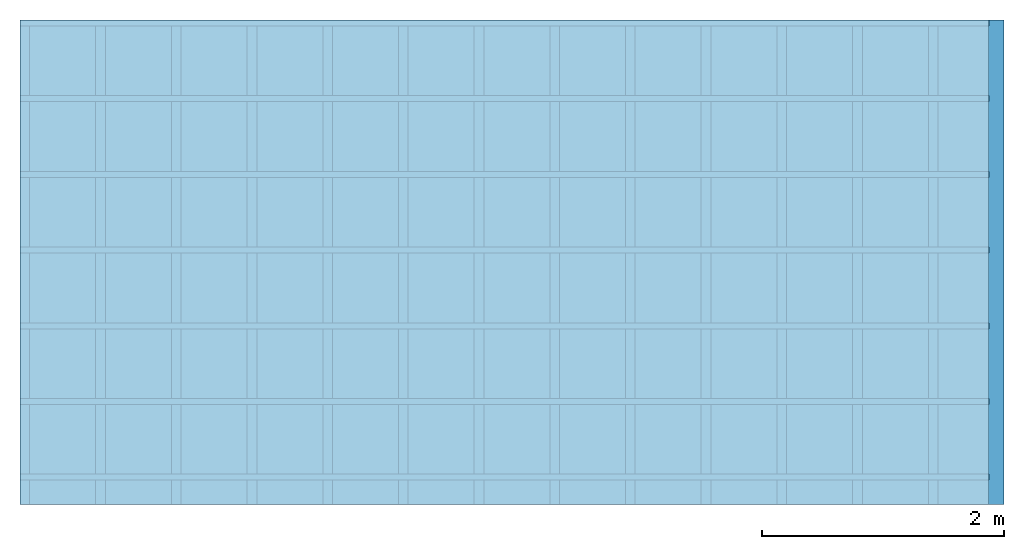
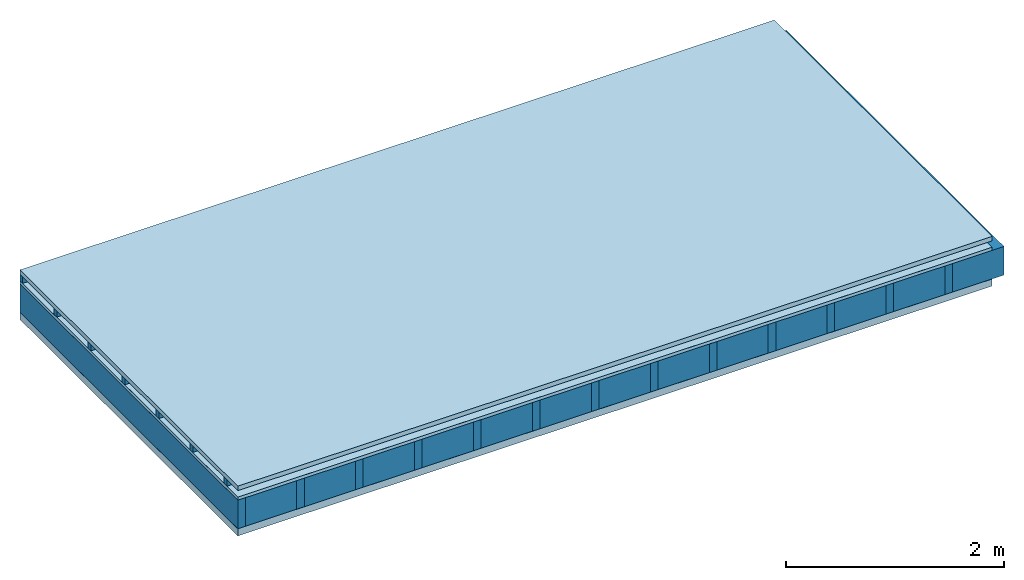
# One storey: 5 plates, 3 members, 1 element without a shape of its own.
"""IFC4 building model written with IfcOpenShell, lengths in metres."""

from ifc_helpers import new_model, si_unit, derived_unit, direction, frame, frame_2d, origin, origin_with_axes, place, context, project, spatial, rectangle, extrude, material, layer, layer_set, type_object, element, aggregate, save


model = new_model("IFC4")

# Units and contexts
plan_context = context("Plan", 3, precision=1e-05, world=origin(), true_north=direction((0.0, 1.0)))
model_context = context("Model", 3, precision=1e-05, world=origin(), true_north=direction((0.0, 1.0)))
ifc_project = project(units=[si_unit("LENGTHUNIT", "METRE"), derived_unit("SOUNDPRESSUREUNIT", [(si_unit("PRESSUREUNIT", "PASCAL", prefix="MICRO"), 0)]), si_unit("ENERGYUNIT", "JOULE", prefix="MEGA"), si_unit("MASSUNIT", "GRAM", prefix="KILO"), derived_unit("THERMALTRANSMITTANCEUNIT", [(si_unit("POWERUNIT", "WATT"), 1), (si_unit("AREAUNIT", "SQUARE_METRE"), -1), (si_unit("THERMODYNAMICTEMPERATUREUNIT", "KELVIN"), -1)]), derived_unit("AREADENSITYUNIT", [(si_unit("MASSUNIT", "GRAM", prefix="KILO"), 1), (si_unit("AREAUNIT", "SQUARE_METRE"), -1)]), derived_unit("USERDEFINED", [(si_unit("ENERGYUNIT", "JOULE", prefix="MEGA"), 1), (si_unit("AREAUNIT", "SQUARE_METRE"), -1)])], contexts=[plan_context, model_context])

# Site, building, storey
site = spatial("IfcSite", under=ifc_project)
building_placement = place(None, origin())
building = spatial("IfcBuilding", under=site, at=building_placement)
storey_placement = place(building_placement, origin())
storey = spatial("IfcBuildingStorey", under=building, at=storey_placement)

# Slab, members, plates
ifc_material_1 = material(Name="Roof tiles", Category="03.015")
ifc_layer_1 = layer(ifc_material_1, 0.05, Name="Roofing")
ifc_layer_2 = layer(None, 0.072, Name="Battens / profiles")
ifc_material_2 = material(Name="Roofing underlay", Category="09.008")
ifc_layer_3 = layer(ifc_material_2, 0.00018, Name="Under the roof")
ifc_material_3 = material(Category="10.009")
ifc_layer_4 = layer(ifc_material_3, 0.035, Name="Sub-floor")
ifc_material_4 = material(Name="of the art")
ifc_layer_5 = layer(ifc_material_4, 0.0, Name="Bond")
ifc_layer_6 = layer(None, 0.32, Name="Supporting structure")
ifc_material_5 = material(Name="Vapor barrier polyethylene (PE)", Category="09.002")
ifc_layer_7 = layer(ifc_material_5, 0.00025, Name="Lower layer 1")
ifc_material_6 = material(Name="Solid timber panel")
ifc_layer_8 = layer(ifc_material_6, 0.08, Name="Lower 2nd layer")
ifc_layer_set = layer_set([ifc_layer_1, ifc_layer_2, ifc_layer_3, ifc_layer_4, ifc_layer_5, ifc_layer_6, ifc_layer_7, ifc_layer_8])
slab_type = type_object("IfcSlabType", Name="E0150", PredefinedType="NOTDEFINED", material=ifc_layer_set)
slab_placement = place(None, frame((0.0, 0.0, 0.0), z_axis=(0.0, 0.0, -1.0), x_axis=(1.0, 0.0, 0.0)))
slab = element("IfcSlab", 1, at=slab_placement, inside=storey, type_object=slab_type, material=ifc_layer_set, Name="Slab #1")
ifc_material_7 = material()
member_1_placement = place(slab_placement, origin())
member_1 = element("IfcMember", 2, at=member_1_placement, material=ifc_material_7, Name="Battens / profiles", context=plan_context, shape_type="SweptSolid", body=[
    extrude(rectangle(XDim=0.05, YDim=0.072, at=frame_2d((0.025, 0.036), x_axis=(1.0, 0.0))), frame((0.0, 0.0, 0.05), z_axis=(1.0, 0.0, 0.0), x_axis=(0.0, 1.0, 0.0)), (0.0, 0.0, 1.0), 8.0),
    extrude(rectangle(XDim=0.05, YDim=0.072, at=frame_2d((0.025, 0.036), x_axis=(1.0, 0.0))), frame((0.0, 0.625, 0.05), z_axis=(1.0, 0.0, 0.0), x_axis=(0.0, 1.0, 0.0)), (0.0, 0.0, 1.0), 8.0),
    extrude(rectangle(XDim=0.05, YDim=0.072, at=frame_2d((0.025, 0.036), x_axis=(1.0, 0.0))), frame((0.0, 1.25, 0.05), z_axis=(1.0, 0.0, 0.0), x_axis=(0.0, 1.0, 0.0)), (0.0, 0.0, 1.0), 8.0),
    extrude(rectangle(XDim=0.05, YDim=0.072, at=frame_2d((0.025, 0.036), x_axis=(1.0, 0.0))), frame((0.0, 1.875, 0.05), z_axis=(1.0, 0.0, 0.0), x_axis=(0.0, 1.0, 0.0)), (0.0, 0.0, 1.0), 8.0),
    extrude(rectangle(XDim=0.05, YDim=0.072, at=frame_2d((0.025, 0.036), x_axis=(1.0, 0.0))), frame((0.0, 2.5, 0.05), z_axis=(1.0, 0.0, 0.0), x_axis=(0.0, 1.0, 0.0)), (0.0, 0.0, 1.0), 8.0),
    extrude(rectangle(XDim=0.05, YDim=0.072, at=frame_2d((0.025, 0.036), x_axis=(1.0, 0.0))), frame((0.0, 3.125, 0.05), z_axis=(1.0, 0.0, 0.0), x_axis=(0.0, 1.0, 0.0)), (0.0, 0.0, 1.0), 8.0),
    extrude(rectangle(XDim=0.05, YDim=0.072, at=frame_2d((0.025, 0.036), x_axis=(1.0, 0.0))), frame((0.0, 3.75, 0.05), z_axis=(1.0, 0.0, 0.0), x_axis=(0.0, 1.0, 0.0)), (0.0, 0.0, 1.0), 8.0),
])
ifc_material_8 = material()
member_2_placement = place(slab_placement, origin())
member_2 = element("IfcMember", 3, at=member_2_placement, material=ifc_material_8, Name="Supporting structure", context=plan_context, shape_type="SweptSolid", body=[
    extrude(rectangle(XDim=0.08, YDim=0.32, at=frame_2d((0.04, 0.16), x_axis=(1.0, 0.0))), frame((0.0, 4.0, 0.15718), z_axis=(0.0, -1.0, 0.0), x_axis=(1.0, 0.0, 0.0)), (0.0, 0.0, 1.0), 4.0),
    extrude(rectangle(XDim=0.08, YDim=0.32, at=frame_2d((0.04, 0.16), x_axis=(1.0, 0.0))), frame((0.625, 4.0, 0.15718), z_axis=(0.0, -1.0, 0.0), x_axis=(1.0, 0.0, 0.0)), (0.0, 0.0, 1.0), 4.0),
    extrude(rectangle(XDim=0.08, YDim=0.32, at=frame_2d((0.04, 0.16), x_axis=(1.0, 0.0))), frame((1.25, 4.0, 0.15718), z_axis=(0.0, -1.0, 0.0), x_axis=(1.0, 0.0, 0.0)), (0.0, 0.0, 1.0), 4.0),
    extrude(rectangle(XDim=0.08, YDim=0.32, at=frame_2d((0.04, 0.16), x_axis=(1.0, 0.0))), frame((1.875, 4.0, 0.15718), z_axis=(0.0, -1.0, 0.0), x_axis=(1.0, 0.0, 0.0)), (0.0, 0.0, 1.0), 4.0),
    extrude(rectangle(XDim=0.08, YDim=0.32, at=frame_2d((0.04, 0.16), x_axis=(1.0, 0.0))), frame((2.5, 4.0, 0.15718), z_axis=(0.0, -1.0, 0.0), x_axis=(1.0, 0.0, 0.0)), (0.0, 0.0, 1.0), 4.0),
    extrude(rectangle(XDim=0.08, YDim=0.32, at=frame_2d((0.04, 0.16), x_axis=(1.0, 0.0))), frame((3.125, 4.0, 0.15718), z_axis=(0.0, -1.0, 0.0), x_axis=(1.0, 0.0, 0.0)), (0.0, 0.0, 1.0), 4.0),
    extrude(rectangle(XDim=0.08, YDim=0.32, at=frame_2d((0.04, 0.16), x_axis=(1.0, 0.0))), frame((3.75, 4.0, 0.15718), z_axis=(0.0, -1.0, 0.0), x_axis=(1.0, 0.0, 0.0)), (0.0, 0.0, 1.0), 4.0),
    extrude(rectangle(XDim=0.08, YDim=0.32, at=frame_2d((0.04, 0.16), x_axis=(1.0, 0.0))), frame((4.375, 4.0, 0.15718), z_axis=(0.0, -1.0, 0.0), x_axis=(1.0, 0.0, 0.0)), (0.0, 0.0, 1.0), 4.0),
    extrude(rectangle(XDim=0.08, YDim=0.32, at=frame_2d((0.04, 0.16), x_axis=(1.0, 0.0))), frame((5.0, 4.0, 0.15718), z_axis=(0.0, -1.0, 0.0), x_axis=(1.0, 0.0, 0.0)), (0.0, 0.0, 1.0), 4.0),
    extrude(rectangle(XDim=0.08, YDim=0.32, at=frame_2d((0.04, 0.16), x_axis=(1.0, 0.0))), frame((5.625, 4.0, 0.15718), z_axis=(0.0, -1.0, 0.0), x_axis=(1.0, 0.0, 0.0)), (0.0, 0.0, 1.0), 4.0),
    extrude(rectangle(XDim=0.08, YDim=0.32, at=frame_2d((0.04, 0.16), x_axis=(1.0, 0.0))), frame((6.25, 4.0, 0.15718), z_axis=(0.0, -1.0, 0.0), x_axis=(1.0, 0.0, 0.0)), (0.0, 0.0, 1.0), 4.0),
    extrude(rectangle(XDim=0.08, YDim=0.32, at=frame_2d((0.04, 0.16), x_axis=(1.0, 0.0))), frame((6.875, 4.0, 0.15718), z_axis=(0.0, -1.0, 0.0), x_axis=(1.0, 0.0, 0.0)), (0.0, 0.0, 1.0), 4.0),
    extrude(rectangle(XDim=0.08, YDim=0.32, at=frame_2d((0.04, 0.16), x_axis=(1.0, 0.0))), frame((7.5, 4.0, 0.15718), z_axis=(0.0, -1.0, 0.0), x_axis=(1.0, 0.0, 0.0)), (0.0, 0.0, 1.0), 4.0),
])
ifc_material_9 = material()
member_3_placement = place(slab_placement, origin())
member_3 = element("IfcMember", 4, at=member_3_placement, material=ifc_material_9, Name="Cavity", context=plan_context, shape_type="SweptSolid", body=[
    extrude(rectangle(XDim=0.545, YDim=0.32, at=frame_2d((0.2725, 0.16), x_axis=(1.0, 0.0))), frame((0.08, 4.0, 0.15718), z_axis=(0.0, -1.0, 0.0), x_axis=(1.0, 0.0, 0.0)), (0.0, 0.0, 1.0), 4.0),
    extrude(rectangle(XDim=0.545, YDim=0.32, at=frame_2d((0.2725, 0.16), x_axis=(1.0, 0.0))), frame((0.705, 4.0, 0.15718), z_axis=(0.0, -1.0, 0.0), x_axis=(1.0, 0.0, 0.0)), (0.0, 0.0, 1.0), 4.0),
    extrude(rectangle(XDim=0.545, YDim=0.32, at=frame_2d((0.2725, 0.16), x_axis=(1.0, 0.0))), frame((1.33, 4.0, 0.15718), z_axis=(0.0, -1.0, 0.0), x_axis=(1.0, 0.0, 0.0)), (0.0, 0.0, 1.0), 4.0),
    extrude(rectangle(XDim=0.545, YDim=0.32, at=frame_2d((0.2725, 0.16), x_axis=(1.0, 0.0))), frame((1.955, 4.0, 0.15718), z_axis=(0.0, -1.0, 0.0), x_axis=(1.0, 0.0, 0.0)), (0.0, 0.0, 1.0), 4.0),
    extrude(rectangle(XDim=0.545, YDim=0.32, at=frame_2d((0.2725, 0.16), x_axis=(1.0, 0.0))), frame((2.58, 4.0, 0.15718), z_axis=(0.0, -1.0, 0.0), x_axis=(1.0, 0.0, 0.0)), (0.0, 0.0, 1.0), 4.0),
    extrude(rectangle(XDim=0.545, YDim=0.32, at=frame_2d((0.2725, 0.16), x_axis=(1.0, 0.0))), frame((3.205, 4.0, 0.15718), z_axis=(0.0, -1.0, 0.0), x_axis=(1.0, 0.0, 0.0)), (0.0, 0.0, 1.0), 4.0),
    extrude(rectangle(XDim=0.545, YDim=0.32, at=frame_2d((0.2725, 0.16), x_axis=(1.0, 0.0))), frame((3.83, 4.0, 0.15718), z_axis=(0.0, -1.0, 0.0), x_axis=(1.0, 0.0, 0.0)), (0.0, 0.0, 1.0), 4.0),
    extrude(rectangle(XDim=0.545, YDim=0.32, at=frame_2d((0.2725, 0.16), x_axis=(1.0, 0.0))), frame((4.455, 4.0, 0.15718), z_axis=(0.0, -1.0, 0.0), x_axis=(1.0, 0.0, 0.0)), (0.0, 0.0, 1.0), 4.0),
    extrude(rectangle(XDim=0.545, YDim=0.32, at=frame_2d((0.2725, 0.16), x_axis=(1.0, 0.0))), frame((5.08, 4.0, 0.15718), z_axis=(0.0, -1.0, 0.0), x_axis=(1.0, 0.0, 0.0)), (0.0, 0.0, 1.0), 4.0),
    extrude(rectangle(XDim=0.545, YDim=0.32, at=frame_2d((0.2725, 0.16), x_axis=(1.0, 0.0))), frame((5.705, 4.0, 0.15718), z_axis=(0.0, -1.0, 0.0), x_axis=(1.0, 0.0, 0.0)), (0.0, 0.0, 1.0), 4.0),
    extrude(rectangle(XDim=0.545, YDim=0.32, at=frame_2d((0.2725, 0.16), x_axis=(1.0, 0.0))), frame((6.33, 4.0, 0.15718), z_axis=(0.0, -1.0, 0.0), x_axis=(1.0, 0.0, 0.0)), (0.0, 0.0, 1.0), 4.0),
    extrude(rectangle(XDim=0.545, YDim=0.32, at=frame_2d((0.2725, 0.16), x_axis=(1.0, 0.0))), frame((6.955, 4.0, 0.15718), z_axis=(0.0, -1.0, 0.0), x_axis=(1.0, 0.0, 0.0)), (0.0, 0.0, 1.0), 4.0),
    extrude(rectangle(XDim=0.545, YDim=0.32, at=frame_2d((0.2725, 0.16), x_axis=(1.0, 0.0))), frame((7.58, 4.0, 0.15718), z_axis=(0.0, -1.0, 0.0), x_axis=(1.0, 0.0, 0.0)), (0.0, 0.0, 1.0), 4.0),
])
plate_1_placement = place(slab_placement, origin())
plate_1 = element("IfcPlate", 5, at=plate_1_placement, material=ifc_material_1, Name="Roofing", context=plan_context, shape_type="SweptSolid", body=[
    extrude(rectangle(XDim=8.0, YDim=4.0, at=frame_2d((4.0, 2.0), x_axis=(1.0, 0.0))), origin_with_axes(), (0.0, 0.0, 1.0), 0.05),
])
plate_2_placement = place(slab_placement, origin())
plate_2 = element("IfcPlate", 6, at=plate_2_placement, material=ifc_material_2, Name="Under the roof", context=plan_context, shape_type="SweptSolid", body=[
    extrude(rectangle(XDim=8.0, YDim=4.0, at=frame_2d((4.0, 2.0), x_axis=(1.0, 0.0))), frame((0.0, 0.0, 0.122), z_axis=(0.0, 0.0, 1.0), x_axis=(1.0, 0.0, 0.0)), (0.0, 0.0, 1.0), 0.00018),
])
plate_3_placement = place(slab_placement, origin())
plate_3 = element("IfcPlate", 7, at=plate_3_placement, material=ifc_material_3, Name="Sub-floor", context=plan_context, shape_type="SweptSolid", body=[
    extrude(rectangle(XDim=8.0, YDim=4.0, at=frame_2d((4.0, 2.0), x_axis=(1.0, 0.0))), frame((0.0, 0.0, 0.12218), z_axis=(0.0, 0.0, 1.0), x_axis=(1.0, 0.0, 0.0)), (0.0, 0.0, 1.0), 0.035),
])
plate_4_placement = place(slab_placement, origin())
plate_4 = element("IfcPlate", 8, at=plate_4_placement, material=ifc_material_5, Name="Lower layer 1", context=plan_context, shape_type="SweptSolid", body=[
    extrude(rectangle(XDim=8.0, YDim=4.0, at=frame_2d((4.0, 2.0), x_axis=(1.0, 0.0))), frame((0.0, 0.0, 0.47718), z_axis=(0.0, 0.0, 1.0), x_axis=(1.0, 0.0, 0.0)), (0.0, 0.0, 1.0), 0.00025),
])
plate_5_placement = place(slab_placement, origin())
plate_5 = element("IfcPlate", 9, at=plate_5_placement, material=ifc_material_6, Name="Lower 2nd layer", context=plan_context, shape_type="SweptSolid", body=[
    extrude(rectangle(XDim=8.0, YDim=4.0, at=frame_2d((4.0, 2.0), x_axis=(1.0, 0.0))), frame((0.0, 0.0, 0.47743), z_axis=(0.0, 0.0, 1.0), x_axis=(1.0, 0.0, 0.0)), (0.0, 0.0, 1.0), 0.08),
])
aggregate(slab, [plate_1, member_1, plate_2, plate_3, member_2, member_3, plate_4, plate_5])

save(model, "model.ifc")
